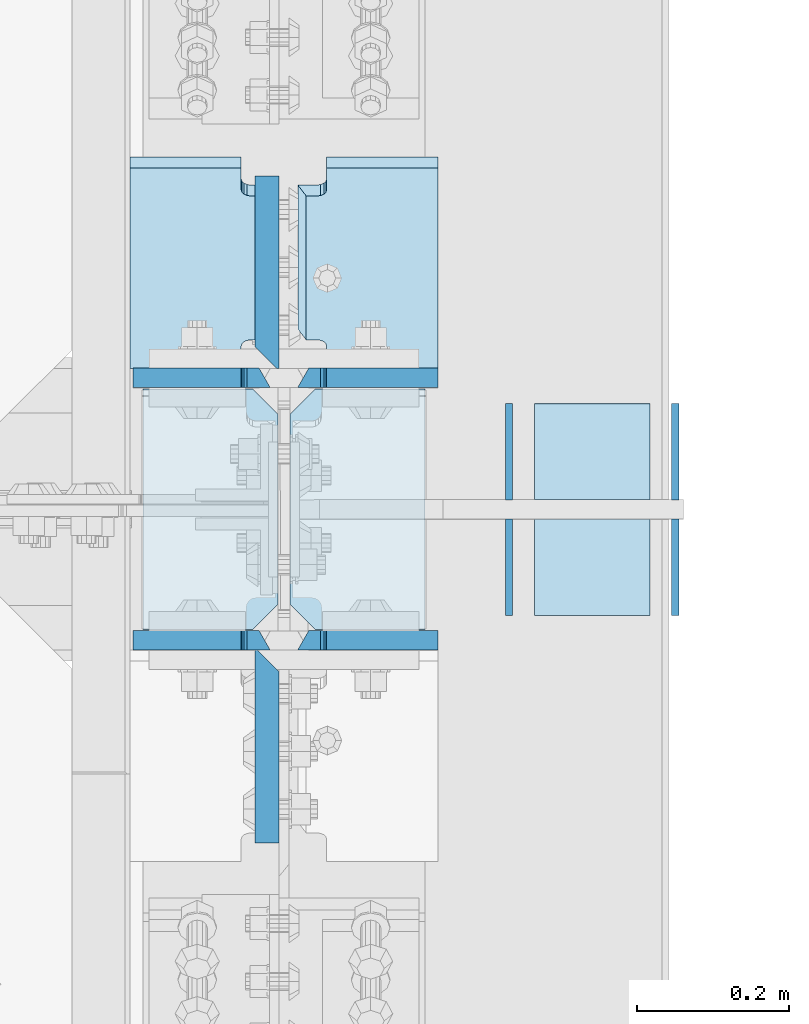
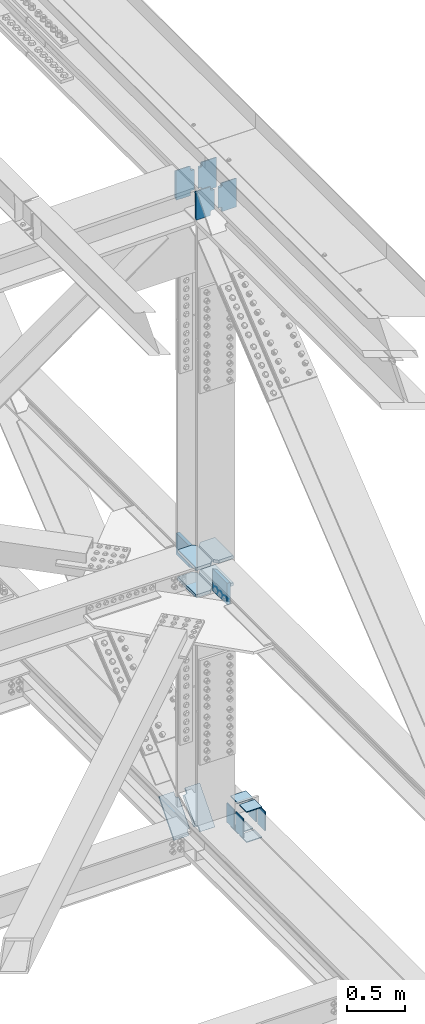
# One storey, part 3614 of 3843: 20 plates, 11 elements without a shape of their own.
"""IFC2X3 building model written with IfcOpenShell, lengths in millimetres."""

from ifc_helpers import new_model, si_unit, frame, origin_with_axes, place, context, subcontext, project, spatial, faceted_brep, material, type_object, element, aggregate, save


model = new_model("IFC2X3")

# Units and contexts
model_context = context("Model", 3, precision=1e-05, world=origin_with_axes())
body_context = subcontext(model_context, "Body", "Model", "MODEL_VIEW")
ifc_project = project(units=[si_unit("LENGTHUNIT", "METRE", prefix="MILLI"), si_unit("AREAUNIT", "SQUARE_METRE"), si_unit("VOLUMEUNIT", "CUBIC_METRE"), si_unit("MASSUNIT", "GRAM", prefix="KILO"), si_unit("TIMEUNIT", "SECOND"), si_unit("PLANEANGLEUNIT", "RADIAN"), si_unit("SOLIDANGLEUNIT", "STERADIAN"), si_unit("THERMODYNAMICTEMPERATUREUNIT", "DEGREE_CELSIUS"), si_unit("LUMINOUSINTENSITYUNIT", "LUMEN")], contexts=[model_context])

# Site, building, storey
site_placement = place(None, origin_with_axes())
site = spatial("IfcSite", under=ifc_project, at=site_placement, CompositionType="ELEMENT")
building_placement = place(site_placement, origin_with_axes())
building = spatial("IfcBuilding", under=site, at=building_placement, Name="Undefined", CompositionType="ELEMENT")
storey_placement = place(building_placement, origin_with_axes())
storey = spatial("IfcBuildingStorey", under=building, at=storey_placement, Name="Undefined", CompositionType="ELEMENT", Elevation=0.0)

# Assembly, plates
assembly_1_placement = place(storey_placement, origin_with_axes())
assembly_1 = element("IfcElementAssembly", 1, at=assembly_1_placement, inside=storey, Name="BEAM", AssemblyPlace="NOTDEFINED", PredefinedType="RIGID_FRAME")
ifc_material = material(Name="STEEL/A572-50")
plate_type_1 = type_object("IfcPlateType", PredefinedType="NOTDEFINED")
plate_1_placement = place(assembly_1_placement, frame((85852.0, 67098.924661095, 46162.0625403493), z_axis=(0.0, 0.00121918199975334, 0.99999925679735), x_axis=(-1.0, 0.0, 0.0)))
plate_1 = element("IfcPlate", 2, at=plate_1_placement, type_object=plate_type_1, material=ifc_material, Name="PLATE", context=body_context, shape_type="Brep", body=[
    faceted_brep([(146.84375, -12.7000000000553, 38.0114858507077), (146.84375, 12.7000000001281, 38.1002327741662), (147.810479922584, 12.7000000001281, 42.9603419576888), (147.810479922584, -12.7000000000553, 42.8715950342303), (150.563493823065, 12.7000000001281, 47.0805435750153), (150.563493823065, -12.7000000000553, 46.9917966515568), (154.683670291226, 12.7000000001281, 49.8335742796335), (154.683670291226, -12.7000000000407, 49.7448273561822), (159.543749809265, 12.7000000001426, 50.8003101030481), (159.543749809265, -12.7000000000407, 50.7115631795969), (184.943749999991, 12.7000000001426, 50.8003101030481), (170.452258242891, -12.7000000000407, 50.7115631795969), (184.943749999991, 12.7000000002081, 263.506216153903), (170.452258242891, -12.699999999837, 263.417469255888), (159.543749809251, 12.6999999992186, 263.506216155103), (159.543749809251, -12.7000000008484, 263.417469232591), (154.683670291211, 12.6999999992113, 264.472951978518), (154.683670291211, -12.7000000008557, 264.384205056005), (150.563493823051, 12.699999999204, 267.225982683158), (150.563493823051, -12.7000000008629, 267.137235760645), (147.810479922569, 12.6999999991895, 271.346184300499), (147.810479922569, -12.7000000008702, 271.257437377986), (146.843749999985, 12.6999999991749, 276.206293484036), (146.843749999985, -12.7000000008848, 276.117546561523), (146.843749999985, 12.70000000039, 304.189248333656), (146.843749999985, -12.6999999998079, 289.697756581867), (0.0, 12.70000000039, 304.189248333656), (0.0, -12.6999999998079, 289.697756581867), (0.0, 12.6999999999971, 0.0), (0.0, -12.7000000000771, 14.4914917543283), (146.843749999985, -12.7000000000771, 14.4914917543283), (146.843749999985, 12.7000000000262, 4.36557456851006e-11)], [[[0, 1, 2, 3]], [[3, 2, 4, 5]], [[5, 4, 6, 7]], [[7, 6, 8, 9]], [[9, 8, 10, 11]], [[12, 13, 11, 10]], [[14, 15, 13, 12]], [[15, 14, 16, 17]], [[17, 16, 18, 19]], [[19, 18, 20, 21]], [[21, 20, 22, 23]], [[24, 25, 23, 22]], [[26, 27, 25, 24]], [[27, 26, 28, 29]], [[0, 3, 5, 7, 9, 11, 13, 15, 17, 19, 21, 23, 25, 27, 29, 30]], [[1, 0, 30, 31]], [[26, 24, 22, 20, 18, 16, 14, 12, 10, 8, 6, 4, 2, 1, 31, 28]], [[30, 29, 28, 31]]]),
])
plate_2_placement = place(assembly_1_placement, frame((85852.0, 67444.9993251475, 46161.5760226403), z_axis=(0.0, 0.00121918199975334, 0.99999925679735), x_axis=(-1.0, 0.0, 0.0)))
plate_2 = element("IfcPlate", 3, at=plate_2_placement, type_object=plate_type_1, material=ifc_material, Name="PLATE", context=body_context, shape_type="Brep", body=[
    faceted_brep([(146.843749999985, 12.7000000004191, 314.319929418722), (0.0, 12.7000000004191, 314.319929418722), (0.0, -12.6999999997788, 299.828437661628), (146.843749999985, -12.6999999997788, 299.828437661628), (146.843749999985, -12.7000000000771, 14.4914917543283), (0.0, -12.7000000000771, 14.4914917543283), (0.0, 12.6999999999971, 0.0), (146.843749999985, 12.7000000000262, 4.36557456851006e-11), (146.843749999985, 12.6999999999098, 38.1890602041385), (146.843749999985, -12.7000000001572, 38.1003132816259), (147.810479922569, 12.6999999998952, 43.0491693876829), (147.810479922569, -12.7000000001644, 42.9604224651703), (150.563493823051, 12.6999999998734, 47.169371005024), (150.563493823051, -12.7000000001863, 47.0806240825113), (154.683670291211, 12.6999999998734, 49.9224017096567), (154.683670291211, -12.7000000001935, 49.833654787144), (159.543749809251, 12.6999999998661, 50.8891375330786), (159.543749809251, -12.7000000001935, 50.800390610566), (184.943749999991, 12.7000000001572, 50.8891375333405), (170.452258242833, -12.7000000000262, 50.800390609882), (184.943749999991, 12.7000000002081, 263.506216153903), (170.452258242891, -12.699999999837, 263.417469255888), (159.543749809251, 12.6999999992186, 263.506216155103), (159.543749809251, -12.7000000008484, 263.417469232591), (154.683670291211, 12.6999999992113, 264.472951978518), (154.683670291211, -12.7000000008557, 264.384205056005), (150.563493823051, 12.699999999204, 267.225982683158), (150.563493823051, -12.7000000008629, 267.137235760645), (147.810479922569, 12.6999999991895, 271.346184300499), (147.810479922569, -12.7000000008702, 271.257437377986), (146.843749999985, 12.6999999991749, 276.206293484036), (146.843749999985, -12.7000000008848, 276.117546561523)], [[[0, 1, 2, 3]], [[4, 5, 6, 7]], [[8, 9, 4, 7]], [[9, 8, 10, 11]], [[11, 10, 12, 13]], [[13, 12, 14, 15]], [[15, 14, 16, 17]], [[17, 16, 18, 19]], [[20, 21, 19, 18]], [[22, 23, 21, 20]], [[23, 22, 24, 25]], [[25, 24, 26, 27]], [[27, 26, 28, 29]], [[29, 28, 30, 31]], [[31, 30, 0, 3]], [[5, 4, 9, 11, 13, 15, 17, 19, 21, 23, 25, 27, 29, 31, 3, 2]], [[6, 5, 2, 1]], [[30, 28, 26, 24, 22, 20, 18, 16, 14, 12, 10, 8, 7, 6, 1, 0]]]),
])

assembly_2_placement = place(storey_placement, origin_with_axes())
assembly_2 = element("IfcElementAssembly", 4, at=assembly_2_placement, inside=storey, Name="BEAM", AssemblyPlace="NOTDEFINED", PredefinedType="RIGID_FRAME")
plate_type_2 = type_object("IfcPlateType", PredefinedType="NOTDEFINED")
plate_3_placement = place(assembly_2_placement, frame((85663.88125, 67729.670534355, 39698.4379802251), z_axis=(0.0, -0.655124373137343, -0.755521049158396), x_axis=(1.0, 0.0, 0.0)))
plate_3 = element("IfcPlate", 5, at=plate_3_placement, type_object=plate_type_2, material=ifc_material, Name="PLATE", context=body_context, shape_type="Brep", body=[
    faceted_brep([(14.2872499999939, 9.52500000008149, 57.1797917327058), (3.17474999999104, -9.52501259184282, 57.1207031871309), (3.17499999998836, -9.52499999931752, 346.694272282257), (14.2874999999913, 9.52500000064174, 346.75336078876), (28.5747501907317, -9.52501330139057, 57.1207031849335), (28.5747501907317, 9.52500000008149, 57.1797917327058), (33.4348297087708, 9.52500000007785, 56.2130571597227), (33.4348297087708, -9.52501352631953, 56.1539686112519), (37.5550061769318, 9.52500000006694, 53.4600300160382), (37.5550061769318, -9.52501389531244, 53.4009414664324), (40.3080200774129, 9.52500000007058, 49.3398337280232), (40.3080200774129, -9.52501435220984, 49.2807451770204), (41.2747499999969, 9.52500000005602, 44.4797308308916), (41.2747499999969, -9.52501482743901, 44.42064227839), (41.2747499999969, 9.52499999997599, 0.990413938867277), (41.2747499999969, -9.5249999999869, 0.990413938867277), (188.118743896484, 9.52499999999054, 0.990413928768248), (188.118743896484, -9.52499999997963, 0.990413928884664), (188.118743896484, 9.5249999992302, 403.874118748543), (188.118743896484, -9.52500000074724, 403.87411874863), (41.2749999999942, 9.5249999992302, 403.874118748543), (41.2749999999942, -9.5249082762748, 403.844547482804), (41.2749999999942, 9.52500000066357, 359.453421690574), (41.2749999999942, -9.52499999929569, 359.394333184071), (40.3082700774103, 9.52500000065629, 354.593318793413), (40.3082700774103, -9.52499999931024, 354.53423028691), (37.5552561769291, 9.52500000064538, 350.473122505427), (37.5552561769291, -9.52499999932115, 350.41403399891), (33.4350797087682, 9.52500000064174, 347.720095361743), (33.4350797087682, -9.52499999932115, 347.66100685524), (28.575000190729, 9.52500000064174, 346.75336078876), (28.575000190729, -9.52499999931752, 346.694272282257)], [[[0, 1, 2, 3]], [[4, 5, 6, 7]], [[7, 6, 8, 9]], [[9, 8, 10, 11]], [[11, 10, 12, 13]], [[13, 12, 14, 15]], [[16, 17, 15, 14]], [[18, 19, 17, 16]], [[19, 18, 20, 21]], [[21, 20, 22, 23]], [[23, 22, 24, 25]], [[25, 24, 26, 27]], [[27, 26, 28, 29]], [[29, 28, 30, 31]], [[4, 7, 9, 11, 13, 15, 17, 19, 21, 23, 25, 27, 29, 31, 2, 1]], [[5, 4, 1, 0]], [[30, 28, 26, 24, 22, 20, 18, 16, 14, 12, 10, 8, 6, 5, 0, 3]], [[31, 30, 3, 2]]]),
])
plate_type_3 = type_object("IfcPlateType", PredefinedType="NOTDEFINED")
plate_4_placement = place(assembly_2_placement, frame((85445.6, 67729.670534355, 39698.4379802251), z_axis=(0.0, -0.655124373137343, -0.755521049158396), x_axis=(1.0, 0.0, 0.0)))
plate_4 = element("IfcPlate", 6, at=plate_4_placement, type_object=plate_type_3, material=ifc_material, Name="PLATE", context=body_context, shape_type="Brep", body=[
    faceted_brep([(184.943743896511, -9.52499999988504, 57.1207032262901), (173.831243896508, 9.52500000007421, 57.1797917327931), (173.831243896508, 9.52500000063446, 346.753360789691), (184.943743896511, -9.52499999932479, 346.694272283188), (154.683664187731, -9.52499999988868, 56.1539686533069), (154.683664187731, 9.52500000007058, 56.21305715981), (159.54374370577, 9.52500000007421, 57.1797917327931), (159.54374370577, -9.52499999988504, 57.1207032262901), (150.56348771957, -9.52499999989232, 53.4009415096225), (150.56348771957, 9.52500000006694, 53.4600300161255), (147.810473819089, -9.52499999990323, 49.2807452216221), (147.810473819089, 9.52500000005602, 49.3398337281251), (146.843743896505, -9.52499999990323, 44.4206423244759), (146.843743896505, 9.52500000005602, 44.479730830979), (146.843749999985, -9.52499999997599, 0.990413928826456), (146.843749999985, 9.52500000000146, 0.990413928739144), (0.0, -9.52499999997599, 0.990413928826456), (0.0, 9.52500000000146, 0.990413928739144), (0.0, -9.52500000073633, 403.87411874863), (0.0, 9.52499999923748, 403.874118748543), (146.843749999985, -9.52500000073633, 403.87411874863), (146.843749999985, 9.52499999923748, 403.874118748543), (146.843743896505, -9.52499999929933, 359.394333185002), (146.843743896505, 9.52500000065629, 359.453421691505), (147.810473819089, -9.5249999993066, 354.534230287856), (147.810473819089, 9.52500000064538, 354.593318794359), (150.56348771957, -9.52499999931752, 350.414033999856), (150.56348771957, 9.52500000064174, 350.473122506359), (154.683664187731, -9.52499999932115, 347.661006856186), (154.683664187731, 9.5250000006381, 347.720095362674), (159.54374370577, -9.52499999932479, 346.694272283188), (159.54374370577, 9.52500000063446, 346.753360789691)], [[[0, 1, 2, 3]], [[4, 5, 6, 7]], [[8, 9, 5, 4]], [[10, 11, 9, 8]], [[12, 13, 11, 10]], [[14, 15, 13, 12]], [[16, 17, 15, 14]], [[18, 19, 17, 16]], [[19, 18, 20, 21]], [[20, 22, 23, 21]], [[24, 25, 23, 22]], [[26, 27, 25, 24]], [[28, 29, 27, 26]], [[30, 31, 29, 28]], [[31, 30, 3, 2]], [[6, 5, 9, 11, 13, 15, 17, 19, 21, 23, 25, 27, 29, 31, 2, 1]], [[7, 6, 1, 0]], [[30, 28, 26, 24, 22, 20, 18, 16, 14, 12, 10, 8, 4, 7, 0, 3]]]),
])
aggregate(assembly_2, [plate_4, plate_3])

# Plate
plate_type_4 = type_object("IfcPlateType", PredefinedType="NOTDEFINED")
plate_5_placement = place(assembly_1_placement, frame((85630.54375, 67098.9246610951, 46162.0625403493), z_axis=(0.0, 0.00121918199975334, 0.99999925679735), x_axis=(-1.0, 0.0, 0.0)))
plate_5 = element("IfcPlate", 7, at=plate_5_placement, type_object=plate_type_4, material=ifc_material, Name="PLATE", context=body_context, shape_type="Brep", body=[
    faceted_brep([(180.974999999991, -12.7000000000844, 14.4914917571878), (38.1000000000058, -12.7000000000771, 14.4914917543283), (38.1000000000058, 12.7000000000262, 4.36557456851006e-11), (180.974999999991, 12.7000000000844, -7.27595761418343e-12), (37.1332700774074, -12.7000000000553, 42.8715950345577), (37.1332700774074, 12.7000000001281, 42.9603419580089), (38.0999999999913, 12.7000000001281, 38.1002327744864), (38.0999999999913, -12.7000000000553, 38.0114858510351), (34.3802561769262, -12.7000000000553, 46.9917966518769), (34.3802561769262, 12.7000000001281, 47.0805435753355), (30.2600797087653, -12.7000000000407, 49.7448273565024), (30.2600797087653, 12.7000000001281, 49.8335742799536), (25.4000001907261, -12.7000000000407, 50.711563179917), (25.4000001907261, 12.7000000001426, 50.8003101033755), (14.4914917571004, -12.7000000000407, 50.711563179917), (0.0, 12.7000000001426, 50.8003101033755), (14.4914917568531, -12.7000000008484, 263.417469232605), (0.0, 12.6999999992186, 263.506216155118), (25.4000001907407, -12.7000000008484, 263.417469232605), (25.4000001907407, 12.6999999992186, 263.506216155118), (30.2600797087798, -12.7000000008557, 264.38420505602), (30.2600797087798, 12.6999999992113, 264.472951978532), (34.3802561769407, -12.7000000008629, 267.13723576066), (34.3802561769407, 12.699999999204, 267.225982683172), (37.1332700774219, -12.7000000008702, 271.257437378001), (37.1332700774219, 12.6999999991895, 271.346184300513), (38.1000000000058, -12.7000000008848, 276.117546561538), (38.1000000000058, 12.6999999991749, 276.206293484051), (38.1000000000058, 12.70000000039, 304.189248333583), (38.1000000000058, -12.6999999998079, 289.697756581794), (180.974999999991, -12.6999999998079, 289.697756581794), (180.974999999991, 12.70000000039, 304.189248333583)], [[[0, 1, 2, 3]], [[4, 5, 6, 7]], [[8, 9, 5, 4]], [[10, 11, 9, 8]], [[12, 13, 11, 10]], [[13, 12, 14, 15]], [[16, 17, 15, 14]], [[18, 19, 17, 16]], [[20, 21, 19, 18]], [[22, 23, 21, 20]], [[24, 25, 23, 22]], [[26, 27, 25, 24]], [[28, 27, 26, 29]], [[30, 31, 28, 29]], [[31, 30, 0, 3]], [[6, 5, 9, 11, 13, 15, 17, 19, 21, 23, 25, 27, 28, 31, 3, 2]], [[7, 6, 2, 1]], [[30, 29, 26, 24, 22, 20, 18, 16, 14, 12, 10, 8, 4, 7, 1, 0]]]),
])

plate_6_placement = place(assembly_1_placement, frame((85630.54375, 67444.9993251476, 46161.5760226403), z_axis=(0.0, 0.00121918199975334, 0.99999925679735), x_axis=(-1.0, 0.0, 0.0)))
plate_6 = element("IfcPlate", 8, at=plate_6_placement, type_object=plate_type_4, material=ifc_material, Name="PLATE", context=body_context, shape_type="Brep", body=[
    faceted_brep([(180.974999999991, -12.7000000000844, 14.4914917571878), (38.1000000000058, -12.7000000000771, 14.4914917543283), (38.1000000000058, 12.7000000000262, 4.36557456851006e-11), (180.974999999991, 12.7000000000844, -7.27595761418343e-12), (37.1332700774219, -12.7000000001644, 42.9604224651848), (37.1332700774219, 12.6999999998952, 43.0491693876975), (38.1000000000058, 12.6999999999098, 38.1890602041531), (38.1000000000058, -12.7000000001572, 38.1003132816404), (34.3802561769407, -12.7000000001863, 47.0806240825259), (34.3802561769407, 12.6999999998734, 47.1693710050386), (30.2600797087798, -12.7000000001935, 49.8336547871586), (30.2600797087798, 12.6999999998734, 49.9224017096712), (25.4000001907407, -12.7000000001935, 50.8003906105805), (25.4000001907407, 12.6999999998661, 50.8891375330932), (14.4914917568531, -12.7000000001935, 50.8003906105805), (0.0, 12.6999999998661, 50.8891375330932), (14.4914917568531, -12.7000000008484, 263.417469232605), (0.0, 12.6999999992186, 263.506216155118), (25.4000001907407, -12.7000000008484, 263.417469232605), (25.4000001907407, 12.6999999992186, 263.506216155118), (30.2600797087798, -12.7000000008557, 264.38420505602), (30.2600797087798, 12.6999999992113, 264.472951978532), (34.3802561769407, -12.7000000008629, 267.13723576066), (34.3802561769407, 12.699999999204, 267.225982683172), (37.1332700774219, -12.7000000008702, 271.257437378001), (37.1332700774219, 12.6999999991895, 271.346184300513), (38.1000000000058, -12.7000000008848, 276.117546561538), (38.1000000000058, 12.6999999991749, 276.206293484051), (38.1000000000058, -12.6997778859077, 299.828565899144), (38.1000000000058, 12.7000000004191, 314.319929418722), (180.974999999991, 12.7000000004191, 314.319929418722), (180.974999999991, -12.6999999997788, 299.828437661628)], [[[0, 1, 2, 3]], [[4, 5, 6, 7]], [[8, 9, 5, 4]], [[10, 11, 9, 8]], [[12, 13, 11, 10]], [[13, 12, 14, 15]], [[16, 17, 15, 14]], [[18, 19, 17, 16]], [[20, 21, 19, 18]], [[22, 23, 21, 20]], [[24, 25, 23, 22]], [[26, 27, 25, 24]], [[27, 26, 28, 29]], [[30, 29, 28, 31]], [[30, 31, 0, 3]], [[6, 5, 9, 11, 13, 15, 17, 19, 21, 23, 25, 27, 29, 30, 3, 2]], [[7, 6, 2, 1]], [[31, 28, 26, 24, 22, 20, 18, 16, 14, 12, 10, 8, 4, 7, 1, 0]]]),
])

aggregate(assembly_1, [plate_1, plate_5, plate_2, plate_6])

# Assembly, plates
assembly_3_placement = place(storey_placement, origin_with_axes())
assembly_3 = element("IfcElementAssembly", 9, at=assembly_3_placement, inside=storey, Name="COLUMN", AssemblyPlace="NOTDEFINED", PredefinedType="RIGID_FRAME")
plate_type_5 = type_object("IfcPlateType", PredefinedType="NOTDEFINED")
plate_7_placement = place(assembly_3_placement, frame((85656.7375000059, 67430.6500962992, 42174.3485285763), z_axis=(0.0, -1.0, 0.0), x_axis=(1.0, 0.0, 0.0)))
plate_7 = element("IfcPlate", 10, at=plate_7_placement, type_object=plate_type_5, material=ifc_material, Name="PLATE", context=body_context, shape_type="Brep", body=[
    faceted_brep([(3.88536136597395e-09, -15.8749999998981, 33.3375015259153), (3.30765033140779e-08, -15.8749999992433, 284.162498473779), (3.30765033140779e-08, 15.8750000007567, 284.162498473699), (3.88536136597395e-09, 15.8750000001019, 33.3375015258353), (33.3375015628408, -15.8749999991487, 317.499999999658), (33.3375015628408, 15.8750000008513, 317.499999999578), (177.800000036965, -15.8749999991487, 317.499999999658), (177.800000036965, 15.8750000008513, 317.499999999578), (177.800003051758, -15.8750000000146, -4.36557456851006e-11), (177.800003051758, 15.8750000000218, 4.36557456851006e-11), (33.3375015258789, -15.8749999999927, 3.63797880709171e-11), (33.3375015258789, 15.8750000000073, -4.36557456851006e-11)], [[[0, 1, 2, 3]], [[1, 4, 5, 2]], [[4, 6, 7, 5]], [[6, 8, 9, 7]], [[8, 10, 11, 9]], [[10, 0, 3, 11]], [[5, 7, 9, 11, 3, 2]], [[10, 8, 6, 4, 1, 0]]]),
])
plate_8_placement = place(assembly_3_placement, frame((85656.7375000059, 67430.6500862987, 42460.0989614372), z_axis=(0.0, -1.0, 0.0), x_axis=(1.0, 0.0, 0.0)))
plate_8 = element("IfcPlate", 11, at=plate_8_placement, type_object=plate_type_5, material=ifc_material, Name="PLATE", context=body_context, shape_type="Brep", body=[
    faceted_brep([(3.88536136597395e-09, -15.8749999998981, 33.3375015259153), (3.30765033140779e-08, -15.8749999992433, 284.162498473779), (3.30765033140779e-08, 15.8750000007567, 284.162498473699), (3.88536136597395e-09, 15.8750000001019, 33.3375015258353), (33.3375015628408, -15.8749999991487, 317.499999999658), (33.3375015628408, 15.8750000008513, 317.499999999578), (177.800000036965, -15.8749999991487, 317.499999999658), (177.800000036965, 15.8750000008513, 317.499999999578), (177.800003051758, -15.8750000000146, -4.36557456851006e-11), (177.800003051758, 15.8750000000218, 4.36557456851006e-11), (33.3375015258789, -15.8749999999927, 3.63797880709171e-11), (33.3375015258789, 15.8750000000073, -4.36557456851006e-11)], [[[0, 1, 2, 3]], [[1, 4, 5, 2]], [[4, 6, 7, 5]], [[6, 8, 9, 7]], [[8, 10, 11, 9]], [[10, 0, 3, 11]], [[5, 7, 9, 11, 3, 2]], [[10, 8, 6, 4, 1, 0]]]),
])
plate_9_placement = place(assembly_3_placement, frame((85463.0625000059, 67430.6500962993, 42174.3485285708), z_axis=(0.0, -1.0, 0.0), x_axis=(1.0, 0.0, 0.0)))
plate_9 = element("IfcPlate", 12, at=plate_9_placement, type_object=plate_type_5, material=ifc_material, Name="PLATE", context=body_context, shape_type="Brep", body=[
    faceted_brep([(0.0, -15.875, 0.0), (0.0, -15.875, 317.5), (0.0, 15.875, 317.5), (0.0, 15.875, 0.0), (144.462498511086, -15.874999999156, 317.499999999665), (144.462498511086, 15.875000000844, 317.499999999578), (177.800000033079, -15.8749999992506, 284.162498473786), (177.800000033079, 15.8750000007494, 284.162498473699), (177.800000003888, -15.8749999999054, 33.3375015259226), (177.800000003888, 15.8750000000946, 33.3375015258353), (144.462498474124, -15.875, 0.0), (144.462498474124, 15.875, 0.0)], [[[0, 1, 2, 3]], [[1, 4, 5, 2]], [[4, 6, 7, 5]], [[6, 8, 9, 7]], [[8, 10, 11, 9]], [[10, 0, 3, 11]], [[5, 7, 9, 11, 3, 2]], [[10, 8, 6, 4, 1, 0]]]),
])
plate_10_placement = place(assembly_3_placement, frame((85463.0625000069, 67430.6500862987, 42460.0989614287), z_axis=(0.0, -1.0, 0.0), x_axis=(1.0, 0.0, 0.0)))
plate_10 = element("IfcPlate", 13, at=plate_10_placement, type_object=plate_type_5, material=ifc_material, Name="PLATE", context=body_context, shape_type="Brep", body=[
    faceted_brep([(0.0, -15.875, 0.0), (0.0, -15.875, 317.5), (0.0, 15.875, 317.5), (0.0, 15.875, 0.0), (144.462498511086, -15.874999999156, 317.499999999665), (144.462498511086, 15.875000000844, 317.499999999578), (177.800000033079, -15.8749999992506, 284.162498473786), (177.800000033079, 15.8750000007494, 284.162498473699), (177.800000003888, -15.8749999999054, 33.3375015259226), (177.800000003888, 15.8750000000946, 33.3375015258353), (144.462498474124, -15.875, 0.0), (144.462498474124, 15.875, 0.0)], [[[0, 1, 2, 3]], [[1, 4, 5, 2]], [[4, 6, 7, 5]], [[6, 8, 9, 7]], [[8, 10, 11, 9]], [[10, 0, 3, 11]], [[5, 7, 9, 11, 3, 2]], [[10, 8, 6, 4, 1, 0]]]),
])
plate_type_6 = type_object("IfcPlateType", PredefinedType="NOTDEFINED")
plate_11_placement = place(assembly_3_placement, frame((85626.575, 67457.6375873347, 42430.7044861098), z_axis=(0.0, 1.0, 0.0), x_axis=(0.0, 0.0, -1.0)))
plate_11 = element("IfcPlate", 14, at=plate_11_placement, type_object=plate_type_6, material=ifc_material, Name="PLATE", context=body_context, shape_type="Brep", body=[
    faceted_brep([(228.600000000064, 15.875, 28.5750007623283), (228.599999999991, -12.7000007629103, -5.82076609134674e-10), (0.0, -12.6999999999971, 0.0), (6.54836185276508e-11, 15.875, 28.5750007629249), (0.0, -15.875, 0.0), (6.69388100504875e-10, -15.875, 254.0), (6.69388100504875e-10, 15.875, 254.0), (228.600000000668, -15.875, 253.999999999403), (228.600000000668, 15.875, 253.999999999403), (228.599999999991, -15.875, -5.82076609134674e-10)], [[[0, 1, 2, 3]], [[4, 5, 6, 3, 2]], [[5, 7, 8, 6]], [[8, 7, 9, 1, 0]], [[9, 4, 2, 1]], [[6, 8, 0, 3]], [[9, 7, 5, 4]]]),
])
plate_12_placement = place(assembly_3_placement, frame((85626.5751061857, 67086.1625873117, 42431.383063099), z_axis=(0.0, -1.0, 0.0), x_axis=(0.0, 0.0, -1.0)))
plate_12 = element("IfcPlate", 15, at=plate_12_placement, type_object=plate_type_6, material=ifc_material, Name="PLATE", context=body_context, shape_type="Brep", body=[
    faceted_brep([(228.600000000064, 15.875, 28.5750007623283), (228.599999999991, -12.700106944947, 5.96628524363041e-10), (-7.27595761418343e-12, -12.700106944947, -1.45519152283669e-11), (6.54836185276508e-11, 15.875, 28.5750007629249), (0.0, -15.875, 0.0), (6.69388100504875e-10, -15.875, 254.0), (6.69388100504875e-10, 15.875, 254.0), (228.600000000668, -15.875, 253.999999999403), (228.600000000668, 15.875, 253.999999999403), (228.599999999991, -15.875, -5.82076609134674e-10)], [[[0, 1, 2, 3]], [[4, 5, 6, 3, 2]], [[5, 7, 8, 6]], [[8, 7, 9, 1, 0]], [[9, 4, 2, 1]], [[6, 8, 0, 3]], [[9, 7, 5, 4]]]),
])
aggregate(assembly_3, [plate_7, plate_8, plate_9, plate_10, plate_11, plate_12])

# Assembly, plate
assembly_4_placement = place(storey_placement, origin_with_axes())
assembly_4 = element("IfcElementAssembly", 16, at=assembly_4_placement, inside=storey, Name="PLATE", AssemblyPlace="NOTDEFINED", PredefinedType="RIGID_FRAME")
plate_type_7 = type_object("IfcPlateType", PredefinedType="NOTDEFINED")
plate_13_placement = place(assembly_4_placement, frame((85945.6625, 67258.9745749442, 39649.8723290576), z_axis=(0.0, -0.999999731324677, 0.000733042000254504), x_axis=(0.0, -0.000733042000252022, -0.999999731324677)))
plate_13 = element("IfcPlate", 17, at=plate_13_placement, type_object=plate_type_7, material=ifc_material, Name="PLATE", context=body_context, shape_type="Brep", body=[
    faceted_brep([(0.0, -4.76249999999709, 0.0), (-0.093096289310779, -4.76249999999709, 126.999965882933), (-0.093096289310779, 4.76249999999709, 126.999965882933), (0.0, 4.76249999999709, 0.0), (203.106849116339, -4.76249999999709, 126.999965883952), (203.106849116339, 4.76249999999709, 126.999965883952), (203.199945405628, -4.76249999999709, 1.00408215075731e-09), (203.199945405628, 4.76249999999709, 1.00408215075731e-09)], [[[0, 1, 2, 3]], [[1, 4, 5, 2]], [[4, 6, 7, 5]], [[6, 0, 3, 7]], [[5, 7, 3, 2]], [[6, 4, 1, 0]]]),
])
aggregate(assembly_4, [plate_13])

assembly_5_placement = place(storey_placement, origin_with_axes())
assembly_5 = element("IfcElementAssembly", 18, at=assembly_5_placement, inside=storey, Name="PLATE", AssemblyPlace="NOTDEFINED", PredefinedType="RIGID_FRAME")
plate_14_placement = place(assembly_5_placement, frame((86164.7375000001, 67258.9745749445, 39649.8723290576), z_axis=(0.0, -0.999999731324677, 0.000733042000254504), x_axis=(0.0, -0.000733042000252022, -0.999999731324677)))
plate_14 = element("IfcPlate", 19, at=plate_14_placement, type_object=plate_type_7, material=ifc_material, Name="PLATE", context=body_context, shape_type="Brep", body=[
    faceted_brep([(0.0, -4.76249999999709, 0.0), (-0.093096289310779, -4.76249999999709, 126.999965882933), (-0.093096289310779, 4.76249999999709, 126.999965882933), (0.0, 4.76249999999709, 0.0), (203.106849116339, -4.76249999999709, 126.999965883952), (203.106849116339, 4.76249999999709, 126.999965883952), (203.199945405628, -4.76249999999709, 1.00408215075731e-09), (203.199945405628, 4.76249999999709, 1.00408215075731e-09)], [[[0, 1, 2, 3]], [[1, 4, 5, 2]], [[4, 6, 7, 5]], [[6, 0, 3, 7]], [[5, 7, 3, 2]], [[6, 4, 1, 0]]]),
])
aggregate(assembly_5, [plate_14])

assembly_6_placement = place(storey_placement, origin_with_axes())
assembly_6 = element("IfcElementAssembly", 20, at=assembly_6_placement, inside=storey, Name="PLATE", AssemblyPlace="NOTDEFINED", PredefinedType="RIGID_FRAME")
plate_15_placement = place(assembly_6_placement, frame((86131.4000000045, 67258.6671852257, 39389.4084175138), z_axis=(0.0, -0.99999892529974, 0.00146608300043589), x_axis=(-1.0, 0.0, 0.0)))
plate_15 = element("IfcPlate", 21, at=plate_15_placement, type_object=plate_type_7, material=ifc_material, Name="PLATE", context=body_context, shape_type="Brep", body=[
    faceted_brep([(0.0, -4.76249999999709, 0.0), (-5.82076609134674e-11, -4.76249999972788, 126.999999995154), (-5.82076609134674e-11, 4.76250000024447, 126.999999995183), (0.0, 4.76249999999709, 0.0), (152.399999999951, -4.76249999972788, 126.999999995154), (152.399999999951, 4.76250000024447, 126.999999995183), (152.399993896484, -4.76249999999709, 0.0), (152.399993896484, 4.76249999999709, 0.0)], [[[0, 1, 2, 3]], [[1, 4, 5, 2]], [[4, 6, 7, 5]], [[6, 0, 3, 7]], [[5, 7, 3, 2]], [[6, 4, 1, 0]]]),
])
aggregate(assembly_6, [plate_15])

assembly_7_placement = place(storey_placement, origin_with_axes())
assembly_7 = element("IfcElementAssembly", 22, at=assembly_7_placement, inside=storey, Name="PLATE", AssemblyPlace="NOTDEFINED", PredefinedType="RIGID_FRAME")
plate_16_placement = place(assembly_7_placement, frame((86131.3999975899, 67259.1343322953, 39706.9081319716), z_axis=(0.0, -0.99999892529974, 0.00146608300043589), x_axis=(-1.0, 0.0, 0.0)))
plate_16 = element("IfcPlate", 23, at=plate_16_placement, type_object=plate_type_7, material=ifc_material, Name="PLATE", context=body_context, shape_type="Brep", body=[
    faceted_brep([(0.0, -4.76249999999709, 0.0), (-5.82076609134674e-11, -4.76249999972788, 126.999999995154), (-5.82076609134674e-11, 4.76250000024447, 126.999999995183), (0.0, 4.76249999999709, 0.0), (152.399999999951, -4.76249999972788, 126.999999995154), (152.399999999951, 4.76250000024447, 126.999999995183), (152.399993896484, -4.76249999999709, 0.0), (152.399993896484, 4.76249999999709, 0.0)], [[[0, 1, 2, 3]], [[1, 4, 5, 2]], [[4, 6, 7, 5]], [[6, 0, 3, 7]], [[5, 7, 3, 2]], [[6, 4, 1, 0]]]),
])
aggregate(assembly_7, [plate_16])

assembly_8_placement = place(storey_placement, origin_with_axes())
assembly_8 = element("IfcElementAssembly", 24, at=assembly_8_placement, inside=storey, Name="PLATE", AssemblyPlace="NOTDEFINED", PredefinedType="RIGID_FRAME")
plate_17_placement = place(assembly_8_placement, frame((85945.6625, 67284.3745712488, 39649.8494208639), z_axis=(0.0, 0.999999731313681, -0.000733057000201368), x_axis=(0.0, -0.000733042000252022, -0.999999731324677)))
plate_17 = element("IfcPlate", 25, at=plate_17_placement, type_object=plate_type_7, material=ifc_material, Name="PLATE", context=body_context, shape_type="Brep", body=[
    faceted_brep([(0.0, -4.76249999999709, 0.0), (0.0930982761929044, -4.76249999999709, 126.999965875119), (0.0930982761929044, 4.76249999999709, 126.999965875119), (0.0, 4.76249999999709, 0.0), (203.293043677208, -4.76249999999709, 126.999965876414), (203.293043677208, 4.76249999999709, 126.999965876414), (203.199945405628, -4.76249999999709, 1.00408215075731e-09), (203.199945405628, 4.76249999999709, 1.00408215075731e-09)], [[[0, 1, 2, 3]], [[1, 4, 5, 2]], [[4, 6, 7, 5]], [[6, 0, 3, 7]], [[5, 7, 3, 2]], [[6, 4, 1, 0]]]),
])
aggregate(assembly_8, [plate_17])

assembly_9_placement = place(storey_placement, origin_with_axes())
assembly_9 = element("IfcElementAssembly", 26, at=assembly_9_placement, inside=storey, Name="PLATE", AssemblyPlace="NOTDEFINED", PredefinedType="RIGID_FRAME")
plate_18_placement = place(assembly_9_placement, frame((86164.7375000001, 67284.374571249, 39649.8494208639), z_axis=(0.0, 0.999999731313681, -0.000733057000201368), x_axis=(0.0, -0.000733042000252022, -0.999999731324677)))
plate_18 = element("IfcPlate", 27, at=plate_18_placement, type_object=plate_type_7, material=ifc_material, Name="PLATE", context=body_context, shape_type="Brep", body=[
    faceted_brep([(0.0, -4.76249999999709, 0.0), (0.0930982761929044, -4.76249999999709, 126.999965875119), (0.0930982761929044, 4.76249999999709, 126.999965875119), (0.0, 4.76249999999709, 0.0), (203.293043677208, -4.76249999999709, 126.999965876414), (203.293043677208, 4.76249999999709, 126.999965876414), (203.199945405628, -4.76249999999709, 1.00408215075731e-09), (203.199945405628, 4.76249999999709, 1.00408215075731e-09)], [[[0, 1, 2, 3]], [[1, 4, 5, 2]], [[4, 6, 7, 5]], [[6, 0, 3, 7]], [[5, 7, 3, 2]], [[6, 4, 1, 0]]]),
])
aggregate(assembly_9, [plate_18])

assembly_10_placement = place(storey_placement, origin_with_axes())
assembly_10 = element("IfcElementAssembly", 28, at=assembly_10_placement, inside=storey, Name="PLATE", AssemblyPlace="NOTDEFINED", PredefinedType="RIGID_FRAME")
plate_19_placement = place(assembly_10_placement, frame((86131.4000000045, 67284.0673710888, 39389.4993223384), z_axis=(0.0, 0.999998925254291, -0.00146611400037364), x_axis=(-1.0, 0.0, 0.0)))
plate_19 = element("IfcPlate", 29, at=plate_19_placement, type_object=plate_type_7, material=ifc_material, Name="PLATE", context=body_context, shape_type="Brep", body=[
    faceted_brep([(0.0, -4.76249999999709, 0.0), (-5.82076609134674e-11, -4.76249999972788, 126.999999995154), (-5.82076609134674e-11, 4.76250000024447, 126.999999995183), (0.0, 4.76249999999709, 0.0), (152.399999999951, -4.76249999972788, 126.999999995154), (152.399999999951, 4.76250000024447, 126.999999995183), (152.399993896484, -4.76249999999709, 0.0), (152.399993896484, 4.76249999999709, 0.0)], [[[0, 1, 2, 3]], [[1, 4, 5, 2]], [[4, 6, 7, 5]], [[6, 0, 3, 7]], [[5, 7, 3, 2]], [[6, 4, 1, 0]]]),
])
aggregate(assembly_10, [plate_19])

assembly_11_placement = place(storey_placement, origin_with_axes())
assembly_11 = element("IfcElementAssembly", 30, at=assembly_11_placement, inside=storey, Name="PLATE", AssemblyPlace="NOTDEFINED", PredefinedType="RIGID_FRAME")
plate_20_placement = place(assembly_11_placement, frame((86131.3999975899, 67284.5328585906, 39706.9993048163), z_axis=(0.0, 0.999998925254291, -0.00146611400037364), x_axis=(-1.0, 0.0, 0.0)))
plate_20 = element("IfcPlate", 31, at=plate_20_placement, type_object=plate_type_7, material=ifc_material, Name="PLATE", context=body_context, shape_type="Brep", body=[
    faceted_brep([(0.0, -4.76249999999709, 0.0), (-5.82076609134674e-11, -4.76249999972788, 126.999999995154), (-5.82076609134674e-11, 4.76250000024447, 126.999999995183), (0.0, 4.76249999999709, 0.0), (152.399999999951, -4.76249999972788, 126.999999995154), (152.399999999951, 4.76250000024447, 126.999999995183), (152.399993896484, -4.76249999999709, 0.0), (152.399993896484, 4.76249999999709, 0.0)], [[[0, 1, 2, 3]], [[1, 4, 5, 2]], [[4, 6, 7, 5]], [[6, 0, 3, 7]], [[5, 7, 3, 2]], [[6, 4, 1, 0]]]),
])
aggregate(assembly_11, [plate_20])

save(model, "model.ifc")
